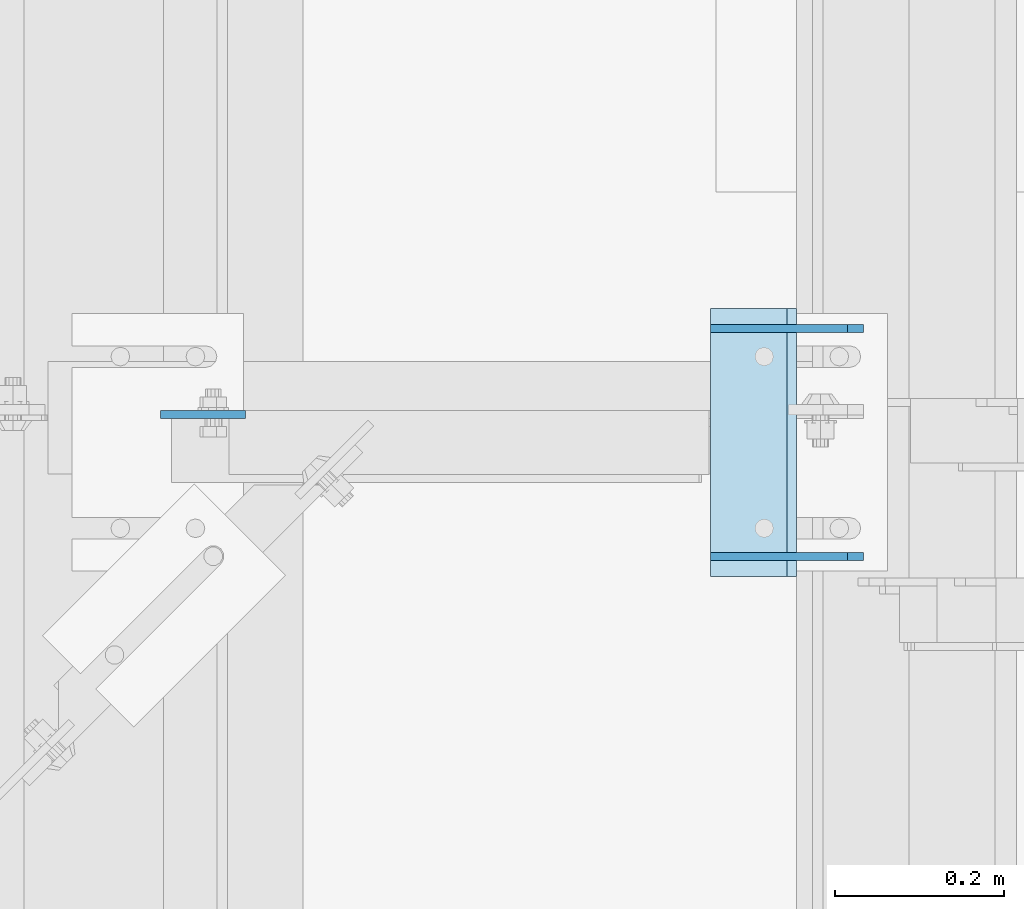
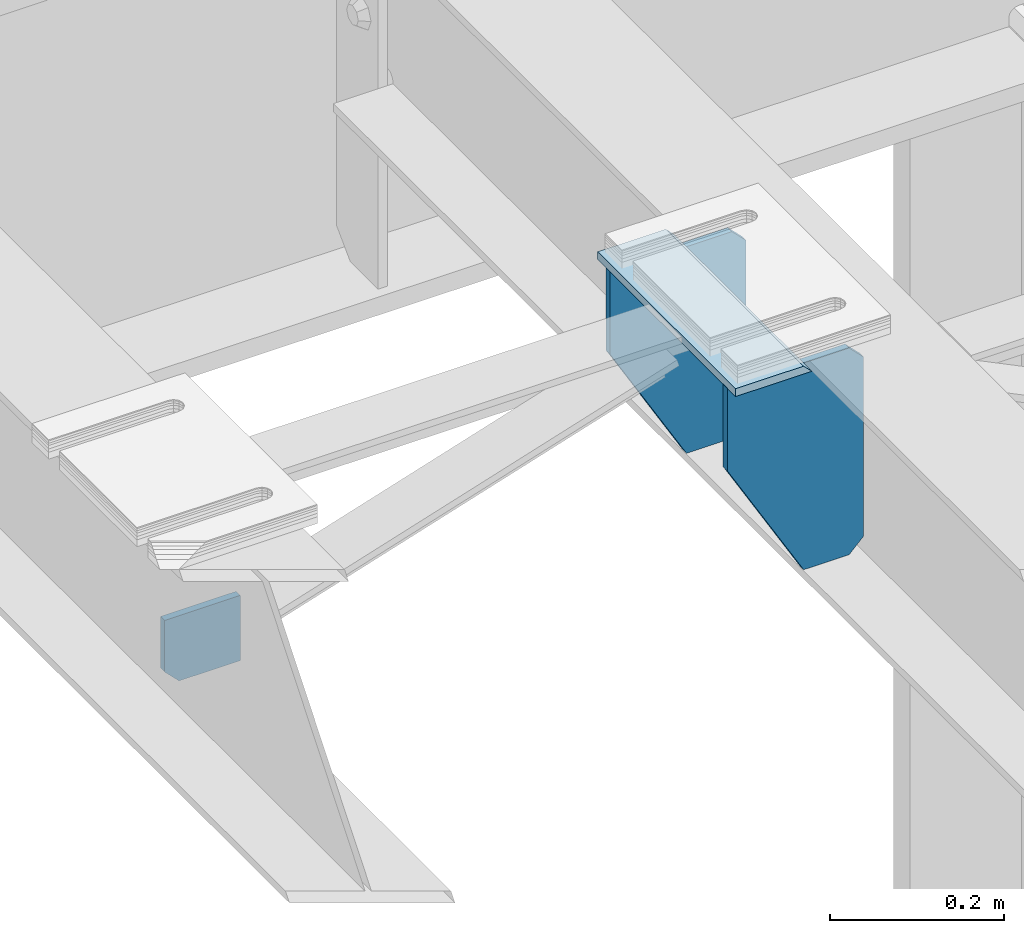
# One storey, part 1725 of 1876: 4 plates, 2 elements without a shape of their own.
"""IFC2X3 building model written with IfcOpenShell, lengths in millimetres."""

from ifc_helpers import new_model, si_unit, frame, origin_with_axes, place, context, subcontext, project, spatial, faceted_brep, material, type_object, element, aggregate, save


model = new_model("IFC2X3")

# Units and contexts
model_context = context("Model", 3, precision=1e-05, world=origin_with_axes())
body_context = subcontext(model_context, "Body", "Model", "MODEL_VIEW")
ifc_project = project(units=[si_unit("LENGTHUNIT", "METRE", prefix="MILLI"), si_unit("AREAUNIT", "SQUARE_METRE"), si_unit("VOLUMEUNIT", "CUBIC_METRE"), si_unit("MASSUNIT", "GRAM", prefix="KILO"), si_unit("TIMEUNIT", "SECOND"), si_unit("PLANEANGLEUNIT", "RADIAN"), si_unit("SOLIDANGLEUNIT", "STERADIAN"), si_unit("THERMODYNAMICTEMPERATUREUNIT", "DEGREE_CELSIUS"), si_unit("LUMINOUSINTENSITYUNIT", "LUMEN")], contexts=[model_context])

# Site, building, storey
site_placement = place(None, origin_with_axes())
site = spatial("IfcSite", under=ifc_project, at=site_placement, CompositionType="ELEMENT")
building_placement = place(site_placement, origin_with_axes())
building = spatial("IfcBuilding", under=site, at=building_placement, Name="Undefined", CompositionType="ELEMENT")
storey_placement = place(building_placement, origin_with_axes())
storey = spatial("IfcBuildingStorey", under=building, at=storey_placement, Name="Undefined", CompositionType="ELEMENT", Elevation=0.0)

# Assembly, plate
assembly_1_placement = place(storey_placement, origin_with_axes())
assembly_1 = element("IfcElementAssembly", 1, at=assembly_1_placement, inside=storey, Name="BEAM", AssemblyPlace="NOTDEFINED", PredefinedType="RIGID_FRAME")
ifc_material = material(Name="STEEL/A36")
plate_type_1 = type_object("IfcPlateType", PredefinedType="NOTDEFINED")
plate_1_placement = place(assembly_1_placement, frame((5730.87497286666, 6594.71795310871, 4919.32790475352), z_axis=(1.0, 0.0, 0.0), x_axis=(0.0, 0.0, -1.0)))
plate_1 = element("IfcPlate", 2, at=plate_1_placement, type_object=plate_type_1, material=ifc_material, Name="PLATE", context=body_context, shape_type="Brep", body=[
    faceted_brep([(0.0, -4.76249999999982, 0.0), (-8.52725042932434e-06, -4.76250000003256, 100.477539062499), (-8.52725042932434e-06, 4.76249999996708, 100.477539062502), (0.0, 4.76249999999982, 0.0), (91.7403945922397, -4.76250000003347, 100.477500915567), (91.7403945922397, 4.76249999996708, 100.47750091557), (91.7404007751775, -4.76250000000709, 19.0499992370687), (91.7404007751775, 4.76249999999345, 19.0499992370724), (72.6904029846191, -4.76250000000073, 6.3664629124105e-12), (72.6904029846191, 4.76249999999891, 1.00044417195022e-11)], [[[0, 1, 2, 3]], [[1, 4, 5, 2]], [[4, 6, 7, 5]], [[6, 8, 9, 7]], [[8, 0, 3, 9]], [[5, 7, 9, 3, 2]], [[8, 6, 4, 1, 0]]]),
])
aggregate(assembly_1, [plate_1])

# Assembly, plates
assembly_2_placement = place(storey_placement, origin_with_axes())
assembly_2 = element("IfcElementAssembly", 3, at=assembly_2_placement, inside=storey, Name="BEAM", AssemblyPlace="NOTDEFINED", PredefinedType="RIGID_FRAME")
plate_type_2 = type_object("IfcPlateType", PredefinedType="NOTDEFINED")
plate_2_placement = place(assembly_2_placement, frame((6381.749997821, 6720.1324182336, 5125.2429934082), z_axis=(1.0, 0.0, 0.0), x_axis=(0.0, -1.0, 0.0)))
plate_2 = element("IfcPlate", 4, at=plate_2_placement, type_object=plate_type_2, material=ifc_material, Name="PLATE", context=body_context, shape_type="Brep", body=[
    faceted_brep([(-6.16536726738559e-06, 5.55599999999959, 101.600006103517), (-5.49103060620837e-06, -5.55599999999959, 90.4875061035173), (317.503753662093, -5.55599999999959, 90.4875213623654), (317.50375366209, 5.55599999999959, 101.600021362366), (0.0, 5.55599999999959, 9.09494701772928e-13), (0.0, -5.55599999999959, 9.09494701772928e-13), (317.50375366211, -5.55599999999959, 1.70075509231538e-10), (317.50375366211, 5.55599999999959, 1.70075509231538e-10)], [[[0, 1, 2, 3]], [[4, 5, 1, 0]], [[6, 7, 3, 2]], [[6, 5, 4, 7]], [[3, 7, 4, 0]], [[5, 6, 2, 1]]]),
])
plate_type_3 = type_object("IfcPlateType", PredefinedType="NOTDEFINED")
plate_3_placement = place(assembly_2_placement, frame((6562.72498580768, 6426.44120750104, 4829.175), z_axis=(-1.0, 0.0, 0.0), x_axis=(0.0, 0.0, 1.0)))
plate_3 = element("IfcPlate", 5, at=plate_3_placement, type_object=plate_type_3, material=ifc_material, Name="PLATE", context=body_context, shape_type="Brep", body=[
    faceted_brep([(0.0, -4.76249999999982, 19.0499992370605), (0.0, -4.76249999999982, 79.375), (0.0, 4.76249999999982, 79.375), (0.0, 4.76249999999982, 19.0499992370605), (174.625, -4.76249999999982, 180.975006103516), (174.625, 4.76249999999982, 180.975006103516), (290.511993408203, -4.76249999999982, 180.975006103516), (290.511993408203, 4.76249999999982, 180.975006103516), (290.511993408203, -4.76249999999982, 19.0499992370605), (290.511993408203, 4.76249999999982, 19.0499992370605), (271.461994171143, -4.76249999999982, 0.0), (271.461994171143, 4.76249999999982, 0.0), (19.0499992370605, -4.76249999999982, 0.0), (19.0499992370605, 4.76249999999982, 0.0)], [[[0, 1, 2, 3]], [[1, 4, 5, 2]], [[4, 6, 7, 5]], [[6, 8, 9, 7]], [[8, 10, 11, 9]], [[10, 12, 13, 11]], [[12, 0, 3, 13]], [[5, 7, 9, 11, 13, 3, 2]], [[12, 10, 8, 6, 4, 1, 0]]]),
])
plate_4_placement = place(assembly_2_placement, frame((6562.72500276248, 6696.3199182336, 4829.175), z_axis=(-1.0, 0.0, 0.0), x_axis=(0.0, 0.0, 1.0)))
plate_4 = element("IfcPlate", 6, at=plate_4_placement, type_object=plate_type_3, material=ifc_material, Name="PLATE", context=body_context, shape_type="Brep", body=[
    faceted_brep([(0.0, -4.76249999999982, 19.0499992370605), (0.0, -4.76249999999982, 79.375), (0.0, 4.76249999999982, 79.375), (0.0, 4.76249999999982, 19.0499992370605), (174.625, -4.76249999999982, 180.975006103516), (174.625, 4.76249999999982, 180.975006103516), (290.511993408203, -4.76249999999982, 180.975006103516), (290.511993408203, 4.76249999999982, 180.975006103516), (290.511993408203, -4.76249999999982, 19.0499992370605), (290.511993408203, 4.76249999999982, 19.0499992370605), (271.461994171143, -4.76249999999982, 0.0), (271.461994171143, 4.76249999999982, 0.0), (19.0499992370605, -4.76249999999982, 0.0), (19.0499992370605, 4.76249999999982, 0.0)], [[[0, 1, 2, 3]], [[1, 4, 5, 2]], [[4, 6, 7, 5]], [[6, 8, 9, 7]], [[8, 10, 11, 9]], [[10, 12, 13, 11]], [[12, 0, 3, 13]], [[5, 7, 9, 11, 13, 3, 2]], [[12, 10, 8, 6, 4, 1, 0]]]),
])
aggregate(assembly_2, [plate_2, plate_3, plate_4])

save(model, "model.ifc")
